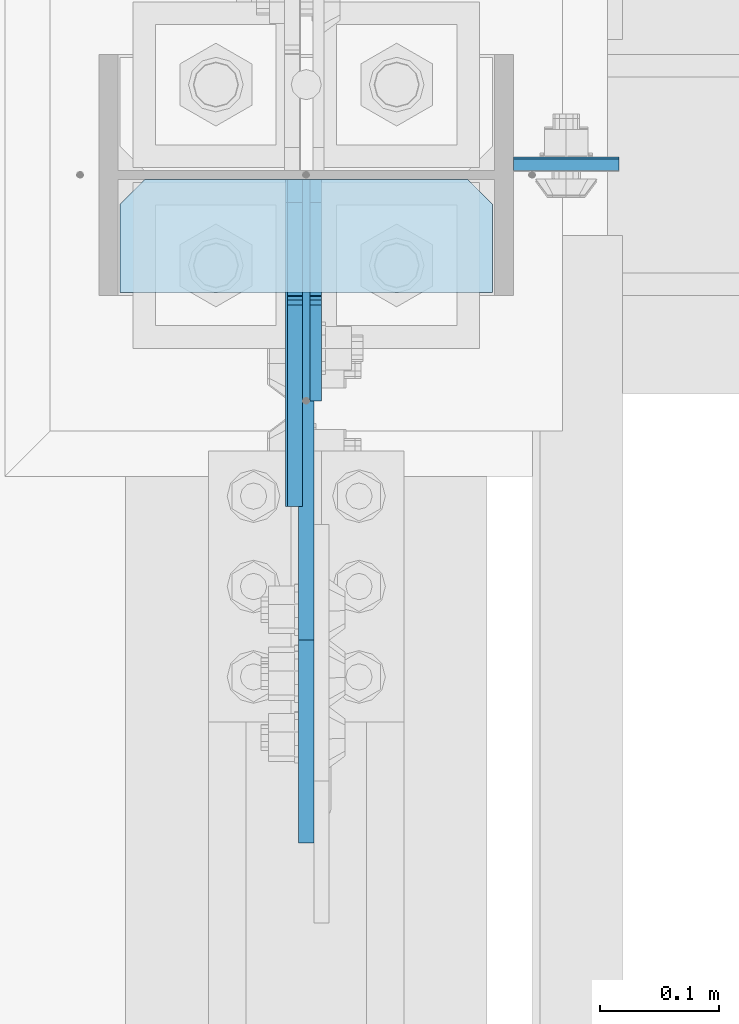
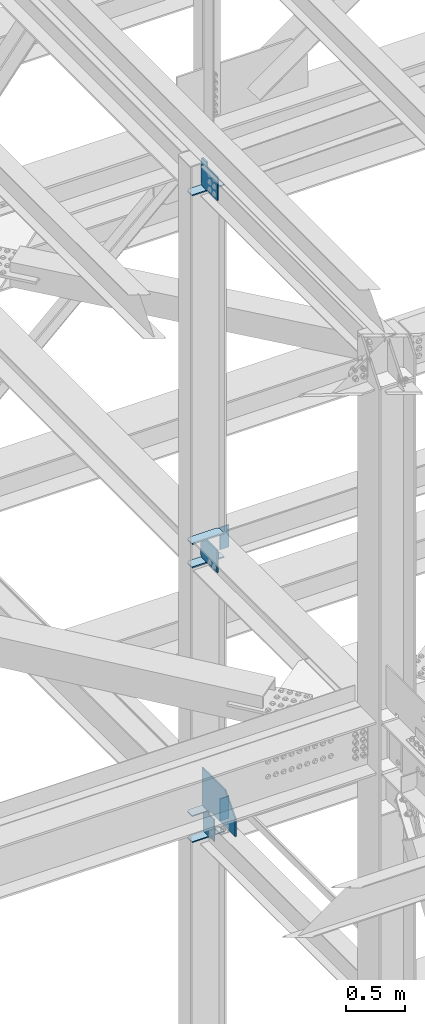
# One storey, part 3202 of 3843: 11 plates, 1 element without a shape of its own.
"""IFC2X3 building model written with IfcOpenShell, lengths in millimetres."""

from ifc_helpers import new_model, si_unit, frame, origin_with_axes, place, context, subcontext, project, spatial, faceted_brep, material, type_object, element, aggregate, save


model = new_model("IFC2X3")

# Units and contexts
model_context = context("Model", 3, precision=1e-05, world=origin_with_axes())
body_context = subcontext(model_context, "Body", "Model", "MODEL_VIEW")
ifc_project = project(units=[si_unit("LENGTHUNIT", "METRE", prefix="MILLI"), si_unit("AREAUNIT", "SQUARE_METRE"), si_unit("VOLUMEUNIT", "CUBIC_METRE"), si_unit("MASSUNIT", "GRAM", prefix="KILO"), si_unit("TIMEUNIT", "SECOND"), si_unit("PLANEANGLEUNIT", "RADIAN"), si_unit("SOLIDANGLEUNIT", "STERADIAN"), si_unit("THERMODYNAMICTEMPERATUREUNIT", "DEGREE_CELSIUS"), si_unit("LUMINOUSINTENSITYUNIT", "LUMEN")], contexts=[model_context])

# Site, building, storey
site_placement = place(None, origin_with_axes())
site = spatial("IfcSite", under=ifc_project, at=site_placement, CompositionType="ELEMENT")
building_placement = place(site_placement, origin_with_axes())
building = spatial("IfcBuilding", under=site, at=building_placement, Name="Undefined", CompositionType="ELEMENT")
storey_placement = place(building_placement, origin_with_axes())
storey = spatial("IfcBuildingStorey", under=building, at=storey_placement, Name="Undefined", CompositionType="ELEMENT", Elevation=0.0)

# Assembly, plates
assembly_placement = place(storey_placement, origin_with_axes())
assembly = element("IfcElementAssembly", 1, at=assembly_placement, inside=storey, Name="COLUMN", AssemblyPlace="NOTDEFINED", PredefinedType="RIGID_FRAME")
ifc_material = material(Name="STEEL/A572-50")
plate_type_1 = type_object("IfcPlateType", PredefinedType="NOTDEFINED")
plate_1_placement = place(assembly_placement, frame((77187.425, 28725.01875, 39573.2), z_axis=(1.0, 0.0, 0.0), x_axis=(0.0, 0.0, -1.0)))
plate_1 = element("IfcPlate", 2, at=plate_1_placement, type_object=plate_type_1, material=ifc_material, Name="PLATE", context=body_context, shape_type="Brep", body=[
    faceted_brep([(0.0, -4.76249999999709, 0.0), (0.0, -4.76249999999709, 88.9000015258789), (0.0, 4.76249999999709, 88.9000015258789), (0.0, 4.76249999999709, 0.0), (228.600006102781, -4.7625000004191, 88.9000015257589), (228.600006102781, 4.76249999954598, 88.9000015257443), (228.600006103079, -4.7625000004482, 7.27595761418343e-12), (228.600006103079, 4.76249999954598, -7.27595761418343e-12)], [[[0, 1, 2, 3]], [[1, 4, 5, 2]], [[4, 6, 7, 5]], [[6, 0, 3, 7]], [[5, 7, 3, 2]], [[6, 4, 1, 0]]]),
])
plate_2_placement = place(assembly_placement, frame((77187.425, 28723.43125, 42360.85), z_axis=(1.0, 0.0, 0.0), x_axis=(0.0, 0.0, -1.0)))
plate_2 = element("IfcPlate", 3, at=plate_2_placement, type_object=plate_type_1, material=ifc_material, Name="PLATE", context=body_context, shape_type="Brep", body=[
    faceted_brep([(0.0, -4.76249999999709, 0.0), (0.0, -4.76249999999709, 88.9000015258789), (0.0, 4.76249999999709, 88.9000015258789), (0.0, 4.76249999999709, 0.0), (228.600006102781, -4.7625000004191, 88.9000015257589), (228.600006102781, 4.76249999954598, 88.9000015257443), (228.600006103079, -4.7625000004482, 7.27595761418343e-12), (228.600006103079, 4.76249999954598, -7.27595761418343e-12)], [[[0, 1, 2, 3]], [[1, 4, 5, 2]], [[4, 6, 7, 5]], [[6, 0, 3, 7]], [[5, 7, 3, 2]], [[6, 4, 1, 0]]]),
])
plate_type_2 = type_object("IfcPlateType", PredefinedType="NOTDEFINED")
plate_3_placement = place(assembly_placement, frame((76855.6375, 28615.48125, 39308.0875), z_axis=(1.0, 0.0, 0.0), x_axis=(0.0, 1.0, 0.0)))
plate_3 = element("IfcPlate", 4, at=plate_3_placement, type_object=plate_type_2, material=ifc_material, Name="PLATE", context=body_context, shape_type="Brep", body=[
    faceted_brep([(0.0, -4.76249999999709, 0.0), (0.0, -4.76249999999709, 314.324999999997), (0.0, 4.76249999999709, 314.324999999997), (0.0, 4.76249999999709, 0.0), (74.6124992370605, -4.76249999999709, 314.324999999997), (74.6124992370605, 4.76249999999709, 314.324999999997), (95.25, -4.76249999999709, 293.687499237058), (95.25, 4.76249999999709, 293.687499237058), (95.25, -4.76249999999709, 20.6375007629395), (95.25, 4.76249999999709, 20.6375007629395), (74.6124992370605, -4.76249999999709, 0.0), (74.6124992370605, 4.76249999999709, 0.0)], [[[0, 1, 2, 3]], [[1, 4, 5, 2]], [[4, 6, 7, 5]], [[6, 8, 9, 7]], [[8, 10, 11, 9]], [[10, 0, 3, 11]], [[5, 7, 9, 11, 3, 2]], [[10, 8, 6, 4, 1, 0]]]),
])
plate_4_placement = place(assembly_placement, frame((76855.6375, 28615.48125, 39574.7875), z_axis=(1.0, 0.0, 0.0), x_axis=(0.0, 1.0, 0.0)))
plate_4 = element("IfcPlate", 5, at=plate_4_placement, type_object=plate_type_2, material=ifc_material, Name="PLATE", context=body_context, shape_type="Brep", body=[
    faceted_brep([(0.0, -4.76249999999709, 0.0), (0.0, -4.76249999999709, 314.324999999997), (0.0, 4.76249999999709, 314.324999999997), (0.0, 4.76249999999709, 0.0), (74.6124992370605, -4.76249999999709, 314.324999999997), (74.6124992370605, 4.76249999999709, 314.324999999997), (95.25, -4.76249999999709, 293.687499237058), (95.25, 4.76249999999709, 293.687499237058), (95.25, -4.76249999999709, 20.6375007629395), (95.25, 4.76249999999709, 20.6375007629395), (74.6124992370605, -4.76249999999709, 0.0), (74.6124992370605, 4.76249999999709, 0.0)], [[[0, 1, 2, 3]], [[1, 4, 5, 2]], [[4, 6, 7, 5]], [[6, 8, 9, 7]], [[8, 10, 11, 9]], [[10, 0, 3, 11]], [[5, 7, 9, 11, 3, 2]], [[10, 8, 6, 4, 1, 0]]]),
])
plate_type_3 = type_object("IfcPlateType", PredefinedType="NOTDEFINED")
plate_5_placement = place(assembly_placement, frame((77012.8, 28710.7312499945, 39579.5499999964), z_axis=(0.0, -1.0, 0.0), x_axis=(0.0, 0.0, 1.0)))
plate_5 = element("IfcPlate", 6, at=plate_5_placement, type_object=plate_type_3, material=ifc_material, Name="PLATE", context=body_context, shape_type="Brep", body=[
    faceted_brep([(19.0499992370605, -6.34999999999854, 0.0), (0.0, -6.34999999999854, 19.0499992370605), (0.0, 6.34999999999854, 19.0499992370605), (19.0499992370605, 6.34999999999854, 0.0), (12.6999999999971, -6.35000000000582, 97.6312499944797), (12.6999999999971, 6.35000000000582, 97.6312499944797), (0.0, 6.35000000000582, 97.6312499944797), (0.0, -6.35000000000582, 97.6312499944797), (12.6999999999971, -6.35000000000582, 558.942504611801), (12.6999999999971, 6.35000000000582, 558.942504612383), (202.550603514726, -6.35000000000582, 558.942504612383), (202.550603514726, 6.35000000000582, 558.942504612383), (390.329885066116, -6.35000000000582, 387.901745084007), (390.329885066116, 6.35000000000582, 387.901745084007), (390.329885066116, -6.35000000000582, 0.0), (390.329885066116, 6.35000000000582, 0.0)], [[[0, 1, 2, 3]], [[4, 5, 6, 7]], [[8, 9, 5, 4]], [[10, 11, 9, 8]], [[10, 12, 13, 11]], [[12, 14, 15, 13]], [[15, 14, 0, 3]], [[6, 5, 9, 11, 13, 15, 3, 2]], [[7, 6, 2, 1]], [[14, 12, 10, 8, 4, 7, 1, 0]]]),
])
plate_type_4 = type_object("IfcPlateType", PredefinedType="NOTDEFINED")
plate_6_placement = place(assembly_placement, frame((76855.6375, 28615.48125, 42127.4875000004), z_axis=(1.0, 0.0, 0.0), x_axis=(0.0, 1.0, 0.0)))
plate_6 = element("IfcPlate", 7, at=plate_6_placement, type_object=plate_type_4, material=ifc_material, Name="PLATE", context=body_context, shape_type="Brep", body=[
    faceted_brep([(0.0, -6.3499999046162, 0.0), (-9.13860276341438e-09, -6.34999999999854, 314.324999999808), (-9.13860276341438e-09, 6.34999999999854, 314.324999999808), (7.27595761418343e-12, 6.3499999046162, 0.0), (74.6124992279219, -6.34999999999854, 314.324999999808), (74.6124992279219, 6.34999999999854, 314.324999999808), (95.2499999914617, -6.34999999999854, 293.687499236868), (95.2499999914617, 6.34999999999854, 293.687499236868), (95.2499999993997, -6.34999999999854, 20.6375007629395), (95.2499999993997, 6.34999999999854, 20.6375007629395), (74.6124992370605, -6.34999999999854, 0.0), (74.6124992370605, 6.34999999999854, 0.0)], [[[0, 1, 2, 3]], [[1, 4, 5, 2]], [[4, 6, 7, 5]], [[6, 8, 9, 7]], [[8, 10, 11, 9]], [[10, 0, 3, 11]], [[5, 7, 9, 11, 3, 2]], [[10, 8, 6, 4, 1, 0]]]),
])
plate_7_placement = place(assembly_placement, frame((76855.6375, 28615.48125, 42368.7875000004), z_axis=(1.0, 0.0, 0.0), x_axis=(0.0, 1.0, 0.0)))
plate_7 = element("IfcPlate", 8, at=plate_7_placement, type_object=plate_type_4, material=ifc_material, Name="PLATE", context=body_context, shape_type="Brep", body=[
    faceted_brep([(0.0, -6.3499999046162, 0.0), (-9.13860276341438e-09, -6.34999999999854, 314.324999999808), (-9.13860276341438e-09, 6.34999999999854, 314.324999999808), (7.27595761418343e-12, 6.3499999046162, 0.0), (74.6124992279219, -6.34999999999854, 314.324999999808), (74.6124992279219, 6.34999999999854, 314.324999999808), (95.2499999914617, -6.34999999999854, 293.687499236868), (95.2499999914617, 6.34999999999854, 293.687499236868), (95.2499999993997, -6.34999999999854, 20.6375007629395), (95.2499999993997, 6.34999999999854, 20.6375007629395), (74.6124992370605, -6.34999999999854, 0.0), (74.6124992370605, 6.34999999999854, 0.0)], [[[0, 1, 2, 3]], [[1, 4, 5, 2]], [[4, 6, 7, 5]], [[6, 8, 9, 7]], [[8, 10, 11, 9]], [[10, 0, 3, 11]], [[5, 7, 9, 11, 3, 2]], [[10, 8, 6, 4, 1, 0]]]),
])
plate_8_placement = place(assembly_placement, frame((76855.6375, 28615.48125, 45946.8205507418), z_axis=(1.0, 0.0, 0.0), x_axis=(0.0, 1.0, 0.0)))
plate_8 = element("IfcPlate", 9, at=plate_8_placement, type_object=plate_type_4, material=ifc_material, Name="PLATE", context=body_context, shape_type="Brep", body=[
    faceted_brep([(0.0, -6.3499999046162, 0.0), (-9.13860276341438e-09, -6.34999999999854, 314.324999999808), (-9.13860276341438e-09, 6.34999999999854, 314.324999999808), (7.27595761418343e-12, 6.3499999046162, 0.0), (74.6124992279219, -6.34999999999854, 314.324999999808), (74.6124992279219, 6.34999999999854, 314.324999999808), (95.2499999914617, -6.34999999999854, 293.687499236868), (95.2499999914617, 6.34999999999854, 293.687499236868), (95.2499999993997, -6.34999999999854, 20.6375007629395), (95.2499999993997, 6.34999999999854, 20.6375007629395), (74.6124992370605, -6.34999999999854, 0.0), (74.6124992370605, 6.34999999999854, 0.0)], [[[0, 1, 2, 3]], [[1, 4, 5, 2]], [[4, 6, 7, 5]], [[6, 8, 9, 7]], [[8, 10, 11, 9]], [[10, 0, 3, 11]], [[5, 7, 9, 11, 3, 2]], [[10, 8, 6, 4, 1, 0]]]),
])
plate_type_5 = type_object("IfcPlateType", PredefinedType="NOTDEFINED")
plate_9_placement = place(assembly_placement, frame((77001.6875, 28710.73125, 42152.8875), z_axis=(0.0, -0.707106781186682, 0.707106781186413), x_axis=(0.0, -0.707106781186548, -0.707106781186548)))
plate_9 = element("IfcPlate", 10, at=plate_9_placement, type_object=plate_type_5, material=ifc_material, Name="PLATE", context=body_context, shape_type="Brep", body=[
    faceted_brep([(0.0, -6.3499999046162, 0.0), (-134.703841815397, -6.35000000000582, 134.703841815395), (-134.703841815397, 6.35000000000582, 134.703841815395), (7.27595761418343e-12, 6.3499999046162, 0.0), (-134.703841815259, -6.35000000000582, 161.644610178604), (-134.703841815259, 6.35000000000582, 161.644610178604), (46.5850786298251, -6.35000000000582, 342.933530623695), (46.5850786298251, 6.35000000000582, 342.933530623695), (208.2296888083, -6.35000000000582, 181.28892044522), (208.2296888083, 6.35000000000582, 181.28892044522), (26.9407683632217, -6.34999999999854, 1.30967237055302e-10), (26.9407683632217, 6.34999999999854, 1.30967237055302e-10)], [[[0, 1, 2, 3]], [[1, 4, 5, 2]], [[4, 6, 7, 5]], [[6, 8, 9, 7]], [[8, 10, 11, 9]], [[10, 0, 3, 11]], [[5, 7, 9, 11, 3, 2]], [[10, 8, 6, 4, 1, 0]]]),
])
plate_type_6 = type_object("IfcPlateType", PredefinedType="NOTDEFINED")
plate_10_placement = place(assembly_placement, frame((77020.7379999161, 28710.73125, 39331.9), z_axis=(0.0, -0.707106781186682, 0.707106781186413), x_axis=(0.0, -0.707106781186548, -0.707106781186548)))
plate_10 = element("IfcPlate", 11, at=plate_10_placement, type_object=plate_type_6, material=ifc_material, Name="PLATE", context=body_context, shape_type="Brep", body=[
    faceted_brep([(0.0, -4.76249999999709, 0.0), (-154.909418087707, -4.76249999999709, 154.909418087706), (-154.909418087707, 4.76249999999709, 154.909418087706), (0.0, 4.76249999999709, 0.0), (-154.909418087576, -4.76249999999709, 181.850186450926), (-154.909418087576, 4.76249999999709, 181.850186450926), (-99.3440833381537, -4.76249999999709, 237.415521200349), (-99.3440833381537, 4.76249999999709, 237.415521200349), (-88.1187630520217, -4.76249999999709, 226.190200914213), (-88.1187630520217, 4.76249999999709, 226.190200914213), (-83.9985865838753, -4.76249999999709, 223.437187013743), (-83.9985865838753, 4.76249999999709, 223.437187013743), (-79.1385070658362, -4.76249999999709, 222.470457091159), (-79.1385070658362, 4.76249999999709, 222.470457091159), (-74.2784275478116, -4.76249999999709, 223.437187013747), (-74.2784275478116, 4.76249999999709, 223.437187013747), (-70.1582510796652, -4.76249999999709, 226.190200914213), (-70.1582510796652, 4.76249999999709, 226.190200914213), (-16.2767142180164, -4.76249999999709, 280.071737775862), (-16.2767142180164, 4.76249999999709, 280.071737775862), (145.367895960451, -4.76249999999709, 118.427127597391), (145.367895960451, 4.76249999999709, 118.427127597391), (26.9407683631998, -4.76249999999709, 1.30967237055302e-10), (26.9407683631998, 4.76249999999709, 1.30967237055302e-10)], [[[0, 1, 2, 3]], [[1, 4, 5, 2]], [[4, 6, 7, 5]], [[6, 8, 9, 7]], [[8, 10, 11, 9]], [[10, 12, 13, 11]], [[12, 14, 15, 13]], [[14, 16, 17, 15]], [[16, 18, 19, 17]], [[18, 20, 21, 19]], [[20, 22, 23, 21]], [[22, 0, 3, 23]], [[5, 7, 9, 11, 13, 15, 17, 19, 21, 23, 3, 2]], [[22, 20, 18, 16, 14, 12, 10, 8, 6, 4, 1, 0]]]),
])
plate_type_7 = type_object("IfcPlateType", PredefinedType="NOTDEFINED")
plate_11_placement = place(assembly_placement, frame((77003.2750001572, 28710.73125, 45972.2205507418), z_axis=(0.0, -0.707106781186682, 0.707106781186413), x_axis=(0.0, -0.707106781186548, -0.707106781186548)))
plate_11 = element("IfcPlate", 12, at=plate_11_placement, type_object=plate_type_7, material=ifc_material, Name="PLATE", context=body_context, shape_type="Brep", body=[
    faceted_brep([(0.0, -6.3499999046162, 0.0), (-177.360058390266, -6.35000000000582, 177.360058390268), (-177.360058390266, 6.35000000000582, 177.360058390268), (7.27595761418343e-12, 6.3499999046162, 0.0), (-177.360058390135, -6.35000000000582, 204.300826753484), (-177.360058390135, 6.35000000000582, 204.300826753484), (-121.794723640713, -6.35000000000582, 259.866161502903), (-121.794723640713, 6.35000000000582, 259.866161502903), (-97.0990191730452, -6.35000000000582, 235.170457035232), (-97.0990191730452, 6.35000000000582, 235.170457035232), (-92.9788427048989, -6.35000000000582, 232.417443134766), (-92.9788427048989, 6.35000000000582, 232.417443134766), (-88.1187631868597, -6.35000000000582, 231.450713212178), (-88.1187631868597, 6.35000000000582, 231.450713212178), (-83.2586836688206, -6.35000000000582, 232.417443134758), (-83.2586836688206, 6.35000000000582, 232.417443134758), (-79.1385072006815, -6.35000000000582, 235.170457035232), (-79.1385072006815, 6.35000000000582, 235.170457035232), (37.6048225087943, -6.35000000000582, 351.913786744693), (37.6048225087943, 6.35000000000582, 351.913786744693), (208.2296888083, -6.35000000000582, 181.28892044522), (208.2296888083, 6.35000000000582, 181.28892044522), (26.9407683632217, -6.34999999999854, 1.30967237055302e-10), (26.9407683632217, 6.34999999999854, 1.30967237055302e-10)], [[[0, 1, 2, 3]], [[1, 4, 5, 2]], [[4, 6, 7, 5]], [[6, 8, 9, 7]], [[8, 10, 11, 9]], [[10, 12, 13, 11]], [[12, 14, 15, 13]], [[14, 16, 17, 15]], [[16, 18, 19, 17]], [[18, 20, 21, 19]], [[20, 22, 23, 21]], [[22, 0, 3, 23]], [[5, 7, 9, 11, 13, 15, 17, 19, 21, 23, 3, 2]], [[22, 20, 18, 16, 14, 12, 10, 8, 6, 4, 1, 0]]]),
])
aggregate(assembly, [plate_1, plate_5, plate_6, plate_7, plate_9, plate_2, plate_3, plate_4, plate_10, plate_8, plate_11])

save(model, "model.ifc")
